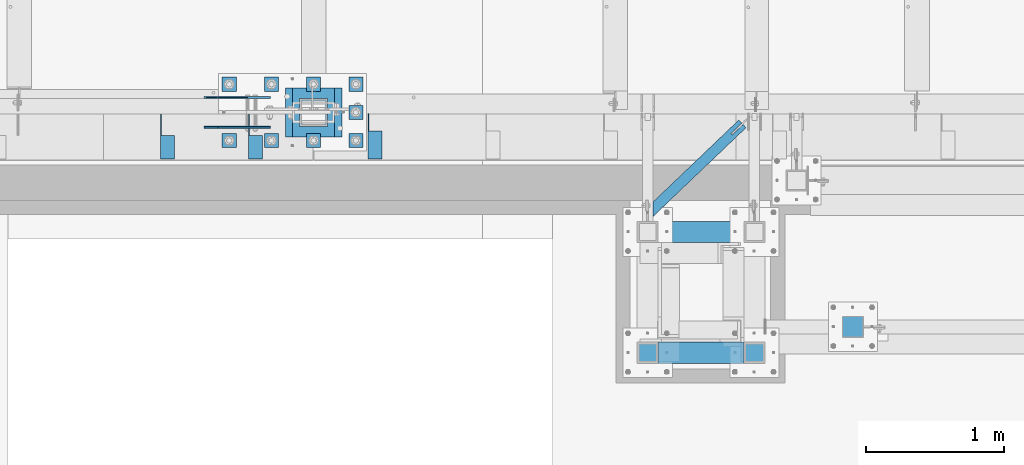
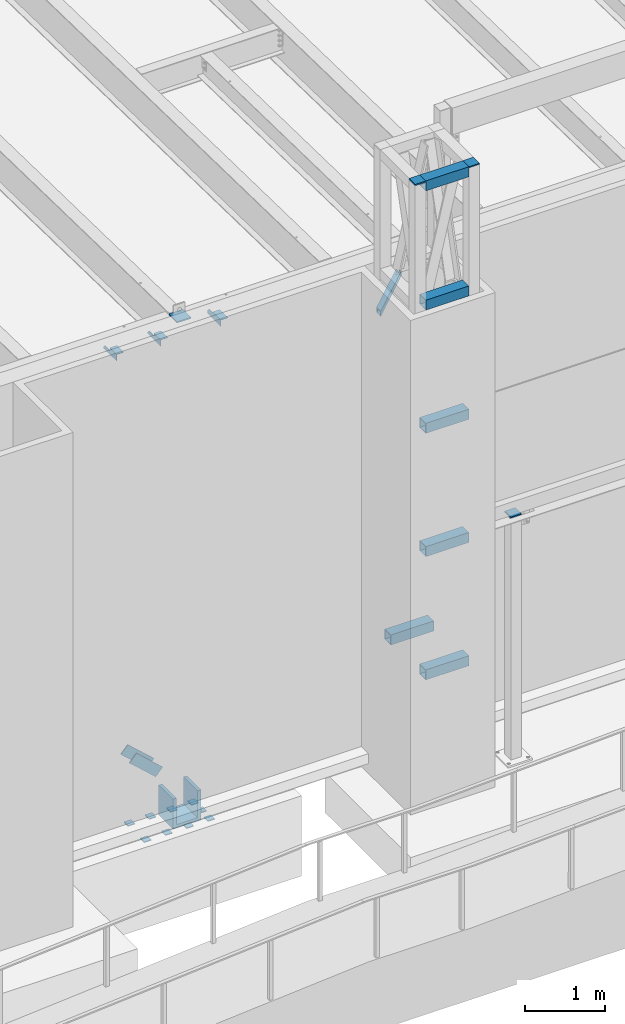
# One storey, part 1179 of 1763: 24 beams, 2 members, 9 elements without a shape of their own.
"""IFC2X3 building model written with IfcOpenShell, lengths in millimetres."""

from ifc_helpers import new_model, si_unit, frame, origin_with_axes, place, context, subcontext, project, spatial, faceted_brep, material, type_object, element, aggregate, save


model = new_model("IFC2X3")

# Units and contexts
model_context = context("Model", 3, precision=1e-05, world=origin_with_axes())
body_context = subcontext(model_context, "Body", "Model", "MODEL_VIEW")
ifc_project = project(units=[si_unit("LENGTHUNIT", "METRE", prefix="MILLI"), si_unit("AREAUNIT", "SQUARE_METRE"), si_unit("VOLUMEUNIT", "CUBIC_METRE"), si_unit("MASSUNIT", "GRAM", prefix="KILO"), si_unit("TIMEUNIT", "SECOND"), si_unit("PLANEANGLEUNIT", "RADIAN"), si_unit("SOLIDANGLEUNIT", "STERADIAN"), si_unit("THERMODYNAMICTEMPERATUREUNIT", "DEGREE_CELSIUS"), si_unit("LUMINOUSINTENSITYUNIT", "LUMEN")], contexts=[model_context])

# Site, building, storey
site_placement = place(None, origin_with_axes())
site = spatial("IfcSite", under=ifc_project, at=site_placement, CompositionType="ELEMENT")
building_placement = place(site_placement, origin_with_axes())
building = spatial("IfcBuilding", under=site, at=building_placement, Name="Undefined", CompositionType="ELEMENT")
storey_placement = place(building_placement, origin_with_axes())
storey = spatial("IfcBuildingStorey", under=building, at=storey_placement, Name="Undefined", CompositionType="ELEMENT", Elevation=0.0)

# Assembly, beam
assembly_1_placement = place(storey_placement, origin_with_axes())
assembly_1 = element("IfcElementAssembly", 1, at=assembly_1_placement, inside=storey, Name="BEAM", AssemblyPlace="NOTDEFINED", PredefinedType="RIGID_FRAME")
ifc_material_1 = material(Name="STEEL/A36")
beam_type_1 = type_object("IfcBeamType", Name="L4X4X1/4", PredefinedType="NOTDEFINED")
beam_1_placement = place(assembly_1_placement, frame((-72047.4055562792, -13723.1435701428, 12153.8999999998), z_axis=(0.0, 0.0, -1.0), x_axis=(0.0, -1.0, 0.0)))
beam_1 = element("IfcBeam", 2, at=beam_1_placement, type_object=beam_type_1, material=ifc_material_1, Name="BRACE", ObjectType="L4X4X1/4", context=body_context, shape_type="Brep", body=[
    faceted_brep([(31.7499999999673, 44.4499999999971, -31.7500001906901), (0.0, 44.4499999999971, -1.90690116141923e-07), (0.0, 50.8000000000029, -1.90690116141923e-07), (31.7499999999673, 50.8000000000029, -31.7500007627295), (-1.96450855582952e-10, 50.8000000000393, 50.7999999999374), (-1.81898940354586e-10, 44.4500000000371, 50.7999999999374), (329.406260681253, 44.4499999999971, 50.7999999999993), (329.406260681253, 50.8000000000029, 50.7999999999993), (329.406260681253, -50.8000000000029, -50.7999999999993), (329.406260681253, -50.8000000000029, -44.4500000000007), (127.793748474225, -50.8000000000029, -44.4500000000007), (127.793748474225, -50.8000000000029, -50.7999999999993), (329.406260681253, 50.8000000000029, -50.7999999999993), (127.793748474225, 50.8000000000029, -50.7999999999993), (329.406260681253, 44.4499999999971, -44.4500000000007), (127.793748474225, 44.4499999999971, -44.4500000000007), (127.793748474227, 44.4499999999971, -31.7500007627295), (127.793748474227, 50.8000000000029, -31.7500007627295)], [[[0, 1, 2, 3]], [[4, 5, 6, 7]], [[8, 9, 10, 11]], [[12, 8, 11, 13]], [[6, 14, 9, 8, 12, 7]], [[9, 14, 15, 10]], [[16, 17, 13, 11, 10, 15]], [[17, 16, 0, 3]], [[4, 7, 12, 13, 17, 3, 2]], [[5, 4, 2, 1]], [[16, 15, 14, 6, 5, 1, 0]]]),
])
aggregate(assembly_1, [beam_1])

# Assembly, beams
assembly_2_placement = place(storey_placement, origin_with_axes())
assembly_2 = element("IfcElementAssembly", 3, at=assembly_2_placement, inside=storey, Name="BEAM", AssemblyPlace="NOTDEFINED", PredefinedType="RIGID_FRAME")
beam_2_placement = place(assembly_2_placement, frame((-72911.0055562792, -13727.9060747206, 12153.8999999998), z_axis=(0.0, 0.0, -1.0), x_axis=(0.0, -1.0, 0.0)))
beam_2 = element("IfcBeam", 4, at=beam_2_placement, type_object=beam_type_1, material=ifc_material_1, Name="BRACE", ObjectType="L4X4X1/4", context=body_context, shape_type="Brep", body=[
    faceted_brep([(156.368743896541, 44.4499999999971, -6.34999904595679), (156.368743896541, 50.8000000000029, -6.34999904595679), (156.368743896533, 50.8000000000029, -50.7999999999993), (156.368743896533, -50.8000000000029, -50.7999999999993), (156.368743896535, -50.8000000000029, -44.4500000000007), (156.368743896535, 44.4499999999971, -44.4500000000007), (31.7499984742426, 44.4500000000007, -6.35000000027321), (31.7499984742426, 50.7999999999993, -6.35000038323415), (-1.81898940354586e-10, 44.4500000000371, 50.7999999999374), (-1.96450855582952e-10, 50.8000000000393, 50.7999999999374), (0.0, 50.7999999999993, 25.3999999997268), (0.0, 44.4500000000007, 25.3999999997268), (324.643737794, 44.4500000000007, 50.7999999999993), (324.643737794, 50.7999999999993, 50.7999999999993), (324.643737794, 44.4500000000007, -44.4500000000007), (324.643737794, -50.7999999999993, -44.4500000000007), (324.643737794, -50.7999999999993, -50.7999999999993), (324.643737794, 50.7999999999993, -50.7999999999993)], [[[0, 1, 2, 3, 4, 5]], [[6, 7, 1, 0]], [[8, 9, 10, 11]], [[9, 8, 12, 13]], [[12, 14, 15, 16, 17, 13]], [[15, 14, 5, 4]], [[16, 15, 4, 3]], [[17, 16, 3, 2]], [[10, 9, 13, 17, 2, 1, 7]], [[6, 11, 10, 7]], [[14, 12, 8, 11, 6, 0, 5]]]),
])
beam_3_placement = place(assembly_2_placement, frame((-73546.0055562792, -13727.9060747205, 12153.8999999998), z_axis=(0.0, 0.0, -1.0), x_axis=(0.0, -1.0, 0.0)))
beam_3 = element("IfcBeam", 5, at=beam_3_placement, type_object=beam_type_1, material=ifc_material_1, Name="BRACE", ObjectType="L4X4X1/4", context=body_context, shape_type="Brep", body=[
    faceted_brep([(156.368743896541, 44.4499999999971, -6.34999904595679), (156.368743896541, 50.8000000000029, -6.34999904595679), (156.368743896533, 50.8000000000029, -50.7999999999993), (156.368743896533, -50.8000000000029, -50.7999999999993), (156.368743896535, -50.8000000000029, -44.4500000000007), (156.368743896535, 44.4499999999971, -44.4500000000007), (31.7499984742426, 44.4500000000007, -6.35000000027321), (31.7499984742426, 50.7999999999993, -6.35000038323415), (-1.81898940354586e-10, 44.4500000000371, 50.7999999999374), (-1.96450855582952e-10, 50.8000000000393, 50.7999999999374), (0.0, 50.7999999999993, 25.3999999997268), (0.0, 44.4500000000007, 25.3999999997268), (324.643737794, 44.4500000000007, 50.7999999999993), (324.643737794, 50.7999999999993, 50.7999999999993), (324.643737794, 44.4500000000007, -44.4500000000007), (324.643737794, -50.7999999999993, -44.4500000000007), (324.643737794, -50.7999999999993, -50.7999999999993), (324.643737794, 50.7999999999993, -50.7999999999993)], [[[0, 1, 2, 3, 4, 5]], [[6, 7, 1, 0]], [[8, 9, 10, 11]], [[9, 8, 12, 13]], [[12, 14, 15, 16, 17, 13]], [[15, 14, 5, 4]], [[16, 15, 4, 3]], [[17, 16, 3, 2]], [[10, 9, 13, 17, 2, 1, 7]], [[6, 11, 10, 7]], [[14, 12, 8, 11, 6, 0, 5]]]),
])
aggregate(assembly_2, [beam_2, beam_3])

# Assembly, beam
assembly_3_placement = place(storey_placement, origin_with_axes())
assembly_3 = element("IfcElementAssembly", 6, at=assembly_3_placement, inside=storey, Name="BEAM", AssemblyPlace="NOTDEFINED", PredefinedType="RIGID_FRAME")
ifc_material_2 = material()
beam_type_2 = type_object("IfcBeamType", Name="HSS3X3X1/4", PredefinedType="NOTDEFINED")
beam_4_placement = place(assembly_3_placement, frame((-70078.0368719919, -14452.5992675181, 11825.2875), z_axis=(0.0, 0.0, 1.0), x_axis=(0.723320631729244, 0.690512319741514, 0.0)))
beam_4 = element("IfcBeam", 7, at=beam_4_placement, type_object=beam_type_2, material=ifc_material_2, Name="BEAM", ObjectType="HSS3X3X1/4", context=body_context, shape_type="Brep", body=[
    faceted_brep([(946.871423137745, 6.35000031700474, 38.1000000000004), (838.921423119747, 6.35000023934117, 38.1000000000004), (838.921423119747, 6.35000023933389, 31.75), (946.871423137745, 6.35000031700474, 31.75), (838.921423128813, -6.34999976050312, 38.1000000000004), (838.921423128799, -6.34999976049585, 31.75), (946.871423137658, -6.34999968283228, 38.1000000000004), (946.871423137658, -6.34999968283228, 31.75), (946.871423137745, 6.35000031700474, -31.75), (838.92142311966, 6.35000023933389, -31.75), (838.921423119638, 6.35000023933389, -38.1000000000004), (946.871423137745, 6.35000031700474, -38.1000000000004), (838.921423128711, -6.3499997605104, -31.75), (838.921423128697, -6.34999976049585, -38.1000000000004), (946.871423137658, -6.34999968283228, -31.75), (946.871423137658, -6.34999968283228, -38.1000000000004), (82.9836498048971, 31.75, 31.75), (82.9836498048971, 31.75, -31.75), (946.871423137905, 31.7500000014479, -31.75), (946.871423137905, 31.7500000014479, 31.75), (946.871423137498, -31.7499999982829, 31.75), (22.3638470663718, -31.7499999998254, 31.75), (22.3638470663718, -31.7499999998254, -31.75), (946.871423137498, -31.7499999982829, -31.75), (16.3018667925207, -38.0999999998094, -38.1000000000004), (16.3018667925207, -38.0999999998094, 38.1000000000004), (89.0456300787482, 38.099999999984, 38.1000000000004), (89.0456300787482, 38.099999999984, -38.1000000000004), (946.871423137949, 38.1000000014174, 38.1000000000004), (946.871423137949, 38.1000000014174, -38.1000000000004), (946.871423137447, -38.0999999982596, -38.1000000000004), (946.871423137447, -38.0999999982596, 38.1000000000004)], [[[0, 1, 2, 3]], [[4, 5, 2, 1]], [[6, 7, 5, 4]], [[8, 9, 10, 11]], [[12, 13, 10, 9]], [[14, 15, 13, 12]], [[16, 17, 18, 19]], [[20, 21, 16, 19, 3, 2, 5, 7]], [[22, 21, 20, 23]], [[9, 8, 18, 17, 22, 23, 14, 12]], [[24, 25, 26, 27], [16, 21, 22, 17]], [[27, 26, 28, 29]], [[19, 18, 8, 11, 29, 28, 0, 3]], [[30, 24, 27, 29, 11, 10, 13, 15]], [[25, 24, 30, 31]], [[1, 0, 28, 26, 25, 31, 6, 4]], [[31, 30, 15, 14, 23, 20, 7, 6]]]),
])
aggregate(assembly_3, [beam_4])

assembly_4_placement = place(storey_placement, origin_with_axes())
assembly_4 = element("IfcElementAssembly", 8, at=assembly_4_placement, inside=storey, Name="COLUMN", AssemblyPlace="NOTDEFINED", PredefinedType="RIGID_FRAME")
beam_type_3 = type_object("IfcBeamType", PredefinedType="NOTDEFINED")
beam_5_placement = place(assembly_4_placement, frame((-68595.3116892775, -15341.6000613784, 8778.875), z_axis=(1.0, 0.0, 0.0), x_axis=(0.0, 1.0, 0.0)))
beam_5 = element("IfcBeam", 9, at=beam_5_placement, type_object=beam_type_3, material=ifc_material_1, Name="PLATE", context=body_context, shape_type="Brep", body=[
    faceted_brep([(0.0, 9.52499999999964, -76.1999999999971), (0.0, 9.52499999999964, 76.1999999999971), (152.400000000001, 9.52499999999964, 76.1999999999971), (152.400000000001, 9.52499999999964, -76.1999999999971), (0.0, -9.52499999999964, 76.1999999999971), (152.400000000001, -9.52499999999964, 76.1999999999971), (0.0, -9.52499999999964, -76.1999999999971), (152.400000000001, -9.52499999999964, -76.1999999999971)], [[[0, 1, 2, 3]], [[1, 4, 5, 2]], [[4, 6, 7, 5]], [[6, 0, 3, 7]], [[5, 7, 3, 2]], [[6, 4, 1, 0]]]),
])
aggregate(assembly_4, [beam_5])

# Assembly, beams
assembly_5_placement = place(storey_placement, origin_with_axes())
assembly_5 = element("IfcElementAssembly", 10, at=assembly_5_placement, inside=storey, Name="FRAME", AssemblyPlace="NOTDEFINED", PredefinedType="RIGID_FRAME")
beam_6_placement = place(assembly_5_placement, frame((-69306.5116892775, -15528.9242675181, 14468.475), z_axis=(1.0, 0.0, 0.0), x_axis=(0.0, 1.0, 0.0)))
beam_6 = element("IfcBeam", 11, at=beam_6_placement, type_object=beam_type_3, material=ifc_material_1, Name="PLATE", context=body_context, shape_type="Brep", body=[
    faceted_brep([(0.0, 9.52499999999964, -76.1999999999971), (0.0, 9.52499999999964, 76.1999999999971), (152.400000000001, 9.52499999999964, 76.1999999999971), (152.400000000001, 9.52499999999964, -76.1999999999971), (0.0, -9.52499999999964, 76.1999999999971), (152.400000000001, -9.52499999999964, 76.1999999999971), (0.0, -9.52499999999964, -76.1999999999971), (152.400000000001, -9.52499999999964, -76.1999999999971)], [[[0, 1, 2, 3]], [[1, 4, 5, 2]], [[4, 6, 7, 5]], [[6, 0, 3, 7]], [[5, 7, 3, 2]], [[6, 4, 1, 0]]]),
])
beam_7_placement = place(assembly_5_placement, frame((-70078.03688459, -15528.9242675181, 14468.475), z_axis=(1.0, 0.0, 0.0), x_axis=(0.0, 1.0, 0.0)))
beam_7 = element("IfcBeam", 12, at=beam_7_placement, type_object=beam_type_3, material=ifc_material_1, Name="PLATE", context=body_context, shape_type="Brep", body=[
    faceted_brep([(0.0, 9.52499999999964, -76.1999999999971), (0.0, 9.52499999999964, 76.1999999999971), (152.400000000001, 9.52499999999964, 76.1999999999971), (152.400000000001, 9.52499999999964, -76.1999999999971), (0.0, -9.52499999999964, 76.1999999999971), (152.400000000001, -9.52499999999964, 76.1999999999971), (0.0, -9.52499999999964, -76.1999999999971), (152.400000000001, -9.52499999999964, -76.1999999999971)], [[[0, 1, 2, 3]], [[1, 4, 5, 2]], [[4, 6, 7, 5]], [[6, 0, 3, 7]], [[5, 7, 3, 2]], [[6, 4, 1, 0]]]),
])

# Assembly, members
assembly_6_placement = place(storey_placement, origin_with_axes())
assembly_6 = element("IfcElementAssembly", 13, at=assembly_6_placement, inside=storey, Name="V. BRACE", AssemblyPlace="NOTDEFINED", PredefinedType="RIGID_FRAME")
member_type = type_object("IfcMemberType", PredefinedType="NOTDEFINED")
member_1_placement = place(assembly_6_placement, frame((-72855.0508448272, -13823.95, 5460.72534249287), z_axis=(0.671476028756224, 0.0, 0.741026276730974), x_axis=(-0.741026276730974, 0.0, 0.671476028756224)))
member_1 = element("IfcMember", 14, at=member_1_placement, type_object=member_type, material=ifc_material_1, Name="PLATE", context=body_context, shape_type="Brep", body=[
    faceted_brep([(4.36557456851006e-11, 6.35000000000036, -76.2000000000044), (-4.72937244921923e-11, 6.35000000000036, 76.1999999999898), (507.999999999498, 6.35000000000036, 76.1999999995642), (507.999999999589, 6.35000000000036, -76.20000000043), (-4.72937244921923e-11, -6.35000000000036, 76.1999999999898), (507.999999999498, -6.35000000000036, 76.1999999995642), (4.36557456851006e-11, -6.35000000000036, -76.2000000000044), (507.999999999589, -6.35000000000036, -76.20000000043)], [[[0, 1, 2, 3]], [[1, 4, 5, 2]], [[4, 6, 7, 5]], [[6, 0, 3, 7]], [[5, 7, 3, 2]], [[6, 4, 1, 0]]]),
])
member_2_placement = place(assembly_6_placement, frame((-72855.0508448272, -13608.05, 5460.72534249287), z_axis=(0.671476028756224, 0.0, 0.741026276730974), x_axis=(-0.741026276730974, 0.0, 0.671476028756224)))
member_2 = element("IfcMember", 15, at=member_2_placement, type_object=member_type, material=ifc_material_1, Name="PLATE", context=body_context, shape_type="Brep", body=[
    faceted_brep([(4.36557456851006e-11, 6.35000000000036, -76.2000000000044), (-4.72937244921923e-11, 6.35000000000036, 76.1999999999898), (507.999999999498, 6.35000000000036, 76.1999999995642), (507.999999999589, 6.35000000000036, -76.20000000043), (-4.72937244921923e-11, -6.35000000000036, 76.1999999999898), (507.999999999498, -6.35000000000036, 76.1999999995642), (4.36557456851006e-11, -6.35000000000036, -76.2000000000044), (507.999999999589, -6.35000000000036, -76.20000000043)], [[[0, 1, 2, 3]], [[1, 4, 5, 2]], [[4, 6, 7, 5]], [[6, 0, 3, 7]], [[5, 7, 3, 2]], [[6, 4, 1, 0]]]),
])
aggregate(assembly_6, [member_1, member_2])

# Assembly, beams
assembly_7_placement = place(storey_placement, origin_with_axes())
assembly_7 = element("IfcElementAssembly", 16, at=assembly_7_placement, inside=storey, Name="TEMPLATE", AssemblyPlace="NOTDEFINED", PredefinedType="RIGID_FRAME")
beam_type_4 = type_object("IfcBeamType", PredefinedType="NOTDEFINED")
beam_8_placement = place(assembly_7_placement, frame((-73100.6372736984, -13970.0, 4578.35), z_axis=(1.0, 0.0, 0.0), x_axis=(0.0, 1.0, 0.0)))
beam_8 = element("IfcBeam", 17, at=beam_8_placement, type_object=beam_type_4, material=ifc_material_1, Name="WASHER PLATE", context=body_context, shape_type="Brep", body=[
    faceted_brep([(0.0, 6.35000000000036, -50.8000000000029), (0.0, 6.35000000000036, 50.8000000000029), (101.599999999999, 6.35000000000036, 50.8000000000029), (101.599999999999, 6.35000000000036, -50.8000000000029), (0.0, -6.35000000000036, 50.8000000000029), (101.599999999999, -6.35000000000036, 50.8000000000029), (0.0, -6.35000000000036, -50.8000000000029), (101.599999999999, -6.35000000000036, -50.8000000000029)], [[[0, 1, 2, 3]], [[1, 4, 5, 2]], [[4, 6, 7, 5]], [[6, 0, 3, 7]], [[5, 7, 3, 2]], [[6, 4, 1, 0]]]),
])
beam_9_placement = place(assembly_7_placement, frame((-72795.8372736984, -13970.0, 4578.35), z_axis=(1.0, 0.0, 0.0), x_axis=(0.0, 1.0, 0.0)))
beam_9 = element("IfcBeam", 18, at=beam_9_placement, type_object=beam_type_4, material=ifc_material_1, Name="WASHER PLATE", context=body_context, shape_type="Brep", body=[
    faceted_brep([(0.0, 6.35000000000036, -50.8000000000029), (0.0, 6.35000000000036, 50.8000000000029), (101.599999999999, 6.35000000000036, 50.8000000000029), (101.599999999999, 6.35000000000036, -50.8000000000029), (0.0, -6.35000000000036, 50.8000000000029), (101.599999999999, -6.35000000000036, 50.8000000000029), (0.0, -6.35000000000036, -50.8000000000029), (101.599999999999, -6.35000000000036, -50.8000000000029)], [[[0, 1, 2, 3]], [[1, 4, 5, 2]], [[4, 6, 7, 5]], [[6, 0, 3, 7]], [[5, 7, 3, 2]], [[6, 4, 1, 0]]]),
])
beam_10_placement = place(assembly_7_placement, frame((-72491.0372736984, -13970.0, 4578.35), z_axis=(1.0, 0.0, 0.0), x_axis=(0.0, 1.0, 0.0)))
beam_10 = element("IfcBeam", 19, at=beam_10_placement, type_object=beam_type_4, material=ifc_material_1, Name="WASHER PLATE", context=body_context, shape_type="Brep", body=[
    faceted_brep([(0.0, 6.35000000000036, -50.8000000000029), (0.0, 6.35000000000036, 50.8000000000029), (101.599999999999, 6.35000000000036, 50.8000000000029), (101.599999999999, 6.35000000000036, -50.8000000000029), (0.0, -6.35000000000036, 50.8000000000029), (101.599999999999, -6.35000000000036, 50.8000000000029), (0.0, -6.35000000000036, -50.8000000000029), (101.599999999999, -6.35000000000036, -50.8000000000029)], [[[0, 1, 2, 3]], [[1, 4, 5, 2]], [[4, 6, 7, 5]], [[6, 0, 3, 7]], [[5, 7, 3, 2]], [[6, 4, 1, 0]]]),
])
beam_11_placement = place(assembly_7_placement, frame((-72186.2372736984, -13970.0, 4578.35), z_axis=(1.0, 0.0, 0.0), x_axis=(0.0, 1.0, 0.0)))
beam_11 = element("IfcBeam", 20, at=beam_11_placement, type_object=beam_type_4, material=ifc_material_1, Name="WASHER PLATE", context=body_context, shape_type="Brep", body=[
    faceted_brep([(0.0, 6.35000000000036, -50.8000000000029), (0.0, 6.35000000000036, 50.8000000000029), (101.599999999999, 6.35000000000036, 50.8000000000029), (101.599999999999, 6.35000000000036, -50.8000000000029), (0.0, -6.35000000000036, 50.8000000000029), (101.599999999999, -6.35000000000036, 50.8000000000029), (0.0, -6.35000000000036, -50.8000000000029), (101.599999999999, -6.35000000000036, -50.8000000000029)], [[[0, 1, 2, 3]], [[1, 4, 5, 2]], [[4, 6, 7, 5]], [[6, 0, 3, 7]], [[5, 7, 3, 2]], [[6, 4, 1, 0]]]),
])
beam_12_placement = place(assembly_7_placement, frame((-72186.2372736984, -13766.8, 4578.35), z_axis=(1.0, 0.0, 0.0), x_axis=(0.0, 1.0, 0.0)))
beam_12 = element("IfcBeam", 21, at=beam_12_placement, type_object=beam_type_4, material=ifc_material_1, Name="WASHER PLATE", context=body_context, shape_type="Brep", body=[
    faceted_brep([(0.0, 6.35000000000036, -50.8000000000029), (0.0, 6.35000000000036, 50.8000000000029), (101.599999999999, 6.35000000000036, 50.8000000000029), (101.599999999999, 6.35000000000036, -50.8000000000029), (0.0, -6.35000000000036, 50.8000000000029), (101.599999999999, -6.35000000000036, 50.8000000000029), (0.0, -6.35000000000036, -50.8000000000029), (101.599999999999, -6.35000000000036, -50.8000000000029)], [[[0, 1, 2, 3]], [[1, 4, 5, 2]], [[4, 6, 7, 5]], [[6, 0, 3, 7]], [[5, 7, 3, 2]], [[6, 4, 1, 0]]]),
])
beam_13_placement = place(assembly_7_placement, frame((-73100.6372736984, -13563.6, 4578.35), z_axis=(1.0, 0.0, 0.0), x_axis=(0.0, 1.0, 0.0)))
beam_13 = element("IfcBeam", 22, at=beam_13_placement, type_object=beam_type_4, material=ifc_material_1, Name="WASHER PLATE", context=body_context, shape_type="Brep", body=[
    faceted_brep([(0.0, 6.35000000000036, -50.8000000000029), (0.0, 6.35000000000036, 50.8000000000029), (101.599999999999, 6.35000000000036, 50.8000000000029), (101.599999999999, 6.35000000000036, -50.8000000000029), (0.0, -6.35000000000036, 50.8000000000029), (101.599999999999, -6.35000000000036, 50.8000000000029), (0.0, -6.35000000000036, -50.8000000000029), (101.599999999999, -6.35000000000036, -50.8000000000029)], [[[0, 1, 2, 3]], [[1, 4, 5, 2]], [[4, 6, 7, 5]], [[6, 0, 3, 7]], [[5, 7, 3, 2]], [[6, 4, 1, 0]]]),
])
beam_14_placement = place(assembly_7_placement, frame((-72795.8372736984, -13563.6, 4578.35), z_axis=(1.0, 0.0, 0.0), x_axis=(0.0, 1.0, 0.0)))
beam_14 = element("IfcBeam", 23, at=beam_14_placement, type_object=beam_type_4, material=ifc_material_1, Name="WASHER PLATE", context=body_context, shape_type="Brep", body=[
    faceted_brep([(0.0, 6.35000000000036, -50.8000000000029), (0.0, 6.35000000000036, 50.8000000000029), (101.599999999999, 6.35000000000036, 50.8000000000029), (101.599999999999, 6.35000000000036, -50.8000000000029), (0.0, -6.35000000000036, 50.8000000000029), (101.599999999999, -6.35000000000036, 50.8000000000029), (0.0, -6.35000000000036, -50.8000000000029), (101.599999999999, -6.35000000000036, -50.8000000000029)], [[[0, 1, 2, 3]], [[1, 4, 5, 2]], [[4, 6, 7, 5]], [[6, 0, 3, 7]], [[5, 7, 3, 2]], [[6, 4, 1, 0]]]),
])
beam_15_placement = place(assembly_7_placement, frame((-72491.0372736984, -13563.6, 4578.35), z_axis=(1.0, 0.0, 0.0), x_axis=(0.0, 1.0, 0.0)))
beam_15 = element("IfcBeam", 24, at=beam_15_placement, type_object=beam_type_4, material=ifc_material_1, Name="WASHER PLATE", context=body_context, shape_type="Brep", body=[
    faceted_brep([(0.0, 6.35000000000036, -50.8000000000029), (0.0, 6.35000000000036, 50.8000000000029), (101.599999999999, 6.35000000000036, 50.8000000000029), (101.599999999999, 6.35000000000036, -50.8000000000029), (0.0, -6.35000000000036, 50.8000000000029), (101.599999999999, -6.35000000000036, 50.8000000000029), (0.0, -6.35000000000036, -50.8000000000029), (101.599999999999, -6.35000000000036, -50.8000000000029)], [[[0, 1, 2, 3]], [[1, 4, 5, 2]], [[4, 6, 7, 5]], [[6, 0, 3, 7]], [[5, 7, 3, 2]], [[6, 4, 1, 0]]]),
])
beam_16_placement = place(assembly_7_placement, frame((-72186.2372736984, -13563.6, 4578.35), z_axis=(1.0, 0.0, 0.0), x_axis=(0.0, 1.0, 0.0)))
beam_16 = element("IfcBeam", 25, at=beam_16_placement, type_object=beam_type_4, material=ifc_material_1, Name="WASHER PLATE", context=body_context, shape_type="Brep", body=[
    faceted_brep([(0.0, 6.35000000000036, -50.8000000000029), (0.0, 6.35000000000036, 50.8000000000029), (101.599999999999, 6.35000000000036, 50.8000000000029), (101.599999999999, 6.35000000000036, -50.8000000000029), (0.0, -6.35000000000036, 50.8000000000029), (101.599999999999, -6.35000000000036, 50.8000000000029), (0.0, -6.35000000000036, -50.8000000000029), (101.599999999999, -6.35000000000036, -50.8000000000029)], [[[0, 1, 2, 3]], [[1, 4, 5, 2]], [[4, 6, 7, 5]], [[6, 0, 3, 7]], [[5, 7, 3, 2]], [[6, 4, 1, 0]]]),
])
aggregate(assembly_7, [beam_8, beam_9, beam_10, beam_11, beam_12, beam_13, beam_14, beam_15, beam_16])

# Beam
beam_type_5 = type_object("IfcBeamType", Name="HSS6X6X1/4", PredefinedType="NOTDEFINED")
beam_17_placement = place(assembly_5_placement, frame((-70078.0366892775, -14579.5992675181, 6966.74375), z_axis=(0.0, 0.0, 1.0), x_axis=(1.0, 0.0, 0.0)))
beam_17 = element("IfcBeam", 26, at=beam_17_placement, type_object=beam_type_5, material=ifc_material_2, Name="BEAM", ObjectType="HSS6X6X1/4", context=body_context, shape_type="Brep", body=[
    faceted_brep([(76.1998046874942, 69.8500000000004, -69.8500000000004), (76.1998046874942, -69.8500000000004, -69.8500000000004), (695.325000000012, -69.8500000000004, -69.8500000000004), (695.325000000012, 69.8500000000004, -69.8500000000004), (76.1998046874942, -69.8500000000004, 69.8500000000004), (695.325000000012, -69.8500000000004, 69.8500000000004), (76.1998046874942, 69.8500000000004, 69.8500000000004), (695.325000000012, 69.8500000000004, 69.8500000000004), (76.1998535156017, 76.2000000000007, -76.1999999999998), (76.1998535156017, 76.2000000000007, 76.1999999999998), (695.325048828119, 76.2000000000007, 76.1999999999998), (695.325048828119, 76.2000000000007, -76.1999999999998), (76.1998535156017, -76.2000000000007, 76.1999999999998), (695.325048828119, -76.2000000000007, 76.1999999999998), (76.1998535156017, -76.2000000000007, -76.1999999999998), (695.325048828119, -76.2000000000007, -76.1999999999998)], [[[0, 1, 2, 3]], [[1, 4, 5, 2]], [[4, 6, 7, 5]], [[6, 0, 3, 7]], [[8, 9, 10, 11]], [[9, 12, 13, 10]], [[12, 14, 15, 13]], [[14, 8, 11, 15]], [[13, 15, 11, 10], [5, 7, 3, 2]], [[14, 12, 9, 8], [6, 4, 1, 0]]]),
])

beam_18_placement = place(assembly_5_placement, frame((-70078.0366892775, -15452.7242675181, 6966.74375), z_axis=(0.0, 0.0, 1.0), x_axis=(1.0, 0.0, 0.0)))
beam_18 = element("IfcBeam", 27, at=beam_18_placement, type_object=beam_type_5, material=ifc_material_2, Name="BEAM", ObjectType="HSS6X6X1/4", context=body_context, shape_type="Brep", body=[
    faceted_brep([(76.1998046874942, 69.8500000000004, -69.8500000000004), (76.1998046874942, -69.8500000000004, -69.8500000000004), (695.325000000012, -69.8500000000004, -69.8500000000004), (695.325000000012, 69.8500000000004, -69.8500000000004), (76.1998046874942, -69.8500000000004, 69.8500000000004), (695.325000000012, -69.8500000000004, 69.8500000000004), (76.1998046874942, 69.8500000000004, 69.8500000000004), (695.325000000012, 69.8500000000004, 69.8500000000004), (76.1998535156017, 76.2000000000007, -76.1999999999998), (76.1998535156017, 76.2000000000007, 76.1999999999998), (695.325048828119, 76.2000000000007, 76.1999999999998), (695.325048828119, 76.2000000000007, -76.1999999999998), (76.1998535156017, -76.2000000000007, 76.1999999999998), (695.325048828119, -76.2000000000007, 76.1999999999998), (76.1998535156017, -76.2000000000007, -76.1999999999998), (695.325048828119, -76.2000000000007, -76.1999999999998)], [[[0, 1, 2, 3]], [[1, 4, 5, 2]], [[4, 6, 7, 5]], [[6, 0, 3, 7]], [[8, 9, 10, 11]], [[9, 12, 13, 10]], [[12, 14, 15, 13]], [[14, 8, 11, 15]], [[13, 15, 11, 10], [5, 7, 3, 2]], [[14, 12, 9, 8], [6, 4, 1, 0]]]),
])

beam_19_placement = place(assembly_5_placement, frame((-70078.0366892775, -15452.7242675181, 8840.7875), z_axis=(0.0, 0.0, 1.0), x_axis=(1.0, 0.0, 0.0)))
beam_19 = element("IfcBeam", 28, at=beam_19_placement, type_object=beam_type_5, material=ifc_material_2, Name="BEAM", ObjectType="HSS6X6X1/4", context=body_context, shape_type="Brep", body=[
    faceted_brep([(76.1998046874942, 69.8500000000004, -69.8500000000004), (76.1998046874942, -69.8500000000004, -69.8500000000004), (695.325000000012, -69.8500000000004, -69.8500000000004), (695.325000000012, 69.8500000000004, -69.8500000000004), (76.1998046874942, -69.8500000000004, 69.8500000000004), (695.325000000012, -69.8500000000004, 69.8500000000004), (76.1998046874942, 69.8500000000004, 69.8500000000004), (695.325000000012, 69.8500000000004, 69.8500000000004), (76.1998535156017, 76.2000000000007, -76.1999999999998), (76.1998535156017, 76.2000000000007, 76.1999999999998), (695.325048828119, 76.2000000000007, 76.1999999999998), (695.325048828119, 76.2000000000007, -76.1999999999998), (76.1998535156017, -76.2000000000007, 76.1999999999998), (695.325048828119, -76.2000000000007, 76.1999999999998), (76.1998535156017, -76.2000000000007, -76.1999999999998), (695.325048828119, -76.2000000000007, -76.1999999999998)], [[[0, 1, 2, 3]], [[1, 4, 5, 2]], [[4, 6, 7, 5]], [[6, 0, 3, 7]], [[8, 9, 10, 11]], [[9, 12, 13, 10]], [[12, 14, 15, 13]], [[14, 8, 11, 15]], [[13, 15, 11, 10], [5, 7, 3, 2]], [[14, 12, 9, 8], [6, 4, 1, 0]]]),
])

beam_20_placement = place(assembly_5_placement, frame((-70078.0366892775, -15452.7242675181, 10714.83125), z_axis=(0.0, 0.0, 1.0), x_axis=(1.0, 0.0, 0.0)))
beam_20 = element("IfcBeam", 29, at=beam_20_placement, type_object=beam_type_5, material=ifc_material_2, Name="BEAM", ObjectType="HSS6X6X1/4", context=body_context, shape_type="Brep", body=[
    faceted_brep([(76.1998046874942, 69.8500000000004, -69.8500000000004), (76.1998046874942, -69.8500000000004, -69.8500000000004), (695.325000000012, -69.8500000000004, -69.8500000000004), (695.325000000012, 69.8500000000004, -69.8500000000004), (76.1998046874942, -69.8500000000004, 69.8500000000004), (695.325000000012, -69.8500000000004, 69.8500000000004), (76.1998046874942, 69.8500000000004, 69.8500000000004), (695.325000000012, 69.8500000000004, 69.8500000000004), (76.1998535156017, 76.2000000000007, -76.1999999999998), (76.1998535156017, 76.2000000000007, 76.1999999999998), (695.325048828119, 76.2000000000007, 76.1999999999998), (695.325048828119, 76.2000000000007, -76.1999999999998), (76.1998535156017, -76.2000000000007, 76.1999999999998), (695.325048828119, -76.2000000000007, 76.1999999999998), (76.1998535156017, -76.2000000000007, -76.1999999999998), (695.325048828119, -76.2000000000007, -76.1999999999998)], [[[0, 1, 2, 3]], [[1, 4, 5, 2]], [[4, 6, 7, 5]], [[6, 0, 3, 7]], [[8, 9, 10, 11]], [[9, 12, 13, 10]], [[12, 14, 15, 13]], [[14, 8, 11, 15]], [[13, 15, 11, 10], [5, 7, 3, 2]], [[14, 12, 9, 8], [6, 4, 1, 0]]]),
])

beam_21_placement = place(assembly_5_placement, frame((-70078.0366892775, -15452.7242675181, 14401.8), z_axis=(0.0, 0.0, 1.0), x_axis=(1.0, 0.0, 0.0)))
beam_21 = element("IfcBeam", 30, at=beam_21_placement, type_object=beam_type_5, material=ifc_material_2, Name="BEAM", ObjectType="HSS6X6X1/4", context=body_context, shape_type="Brep", body=[
    faceted_brep([(76.1998046874942, 69.8500000000004, -69.8500000000004), (76.1998046874942, -69.8500000000004, -69.8500000000004), (695.325000000012, -69.8500000000004, -69.8500000000004), (695.325000000012, 69.8500000000004, -69.8500000000004), (76.1998046874942, -69.8500000000004, 69.8500000000004), (695.325000000012, -69.8500000000004, 69.8500000000004), (76.1998046874942, 69.8500000000004, 69.8500000000004), (695.325000000012, 69.8500000000004, 69.8500000000004), (76.1998535156017, 76.2000000000007, -76.1999999999998), (76.1998535156017, 76.2000000000007, 76.1999999999998), (695.325048828119, 76.2000000000007, 76.1999999999998), (695.325048828119, 76.2000000000007, -76.1999999999998), (76.1998535156017, -76.2000000000007, 76.1999999999998), (695.325048828119, -76.2000000000007, 76.1999999999998), (76.1998535156017, -76.2000000000007, -76.1999999999998), (695.325048828119, -76.2000000000007, -76.1999999999998)], [[[0, 1, 2, 3]], [[1, 4, 5, 2]], [[4, 6, 7, 5]], [[6, 0, 3, 7]], [[8, 9, 10, 11]], [[9, 12, 13, 10]], [[12, 14, 15, 13]], [[14, 8, 11, 15]], [[13, 15, 11, 10], [5, 7, 3, 2]], [[14, 12, 9, 8], [6, 4, 1, 0]]]),
])

beam_22_placement = place(assembly_5_placement, frame((-70078.0366892775, -15452.7242675181, 12588.875), z_axis=(0.0, 0.0, 1.0), x_axis=(1.0, 0.0, 0.0)))
beam_22 = element("IfcBeam", 31, at=beam_22_placement, type_object=beam_type_5, material=ifc_material_2, Name="BEAM", ObjectType="HSS6X6X1/4", context=body_context, shape_type="Brep", body=[
    faceted_brep([(76.1998046874942, 69.8500000000004, -69.8500000000004), (76.1998046874942, -69.8500000000004, -69.8500000000004), (695.325000000012, -69.8500000000004, -69.8500000000004), (695.325000000012, 69.8500000000004, -69.8500000000004), (76.1998046874942, -69.8500000000004, 69.8500000000004), (695.325000000012, -69.8500000000004, 69.8500000000004), (76.1998046874942, 69.8500000000004, 69.8500000000004), (695.325000000012, 69.8500000000004, 69.8500000000004), (76.1998535156017, 76.2000000000007, -76.1999999999998), (76.1998535156017, 76.2000000000007, 76.1999999999998), (695.325048828119, 76.2000000000007, 76.1999999999998), (695.325048828119, 76.2000000000007, -76.1999999999998), (76.1998535156017, -76.2000000000007, 76.1999999999998), (695.325048828119, -76.2000000000007, 76.1999999999998), (76.1998535156017, -76.2000000000007, -76.1999999999998), (695.325048828119, -76.2000000000007, -76.1999999999998)], [[[0, 1, 2, 3]], [[1, 4, 5, 2]], [[4, 6, 7, 5]], [[6, 0, 3, 7]], [[8, 9, 10, 11]], [[9, 12, 13, 10]], [[12, 14, 15, 13]], [[14, 8, 11, 15]], [[13, 15, 11, 10], [5, 7, 3, 2]], [[14, 12, 9, 8], [6, 4, 1, 0]]]),
])

aggregate(assembly_5, [beam_17, beam_18, beam_19, beam_20, beam_6, beam_7, beam_21, beam_22])

# Assembly, beam
assembly_8_placement = place(storey_placement, origin_with_axes())
assembly_8 = element("IfcElementAssembly", 32, at=assembly_8_placement, inside=storey, Name="GROUT", AssemblyPlace="NOTDEFINED", PredefinedType="REINFORCEMENT_UNIT")
ifc_material_3 = material(Name="CONCRETE/GROUT")
beam_type_6 = type_object("IfcBeamType", PredefinedType="NOTDEFINED")
beam_23_placement = place(assembly_8_placement, frame((-72668.8372736983, -13716.0325861983, 5029.19999389648), z_axis=(0.0, 1.0, 0.0), x_axis=(0.0, 0.0, -1.0)))
beam_23 = element("IfcBeam", 33, at=beam_23_placement, type_object=beam_type_6, material=ifc_material_3, Name="GROUT", context=body_context, shape_type="Brep", body=[
    faceted_brep([(0.0, -25.4000000000015, -177.799999999999), (0.0, -25.4000000000015, 177.799999999999), (0.0, 25.4000000000015, 177.799999999999), (0.0, 25.4000000000015, -177.799999999999), (457.199993896478, 25.4000000000015, 177.799999999999), (457.199993896478, 25.4000000000015, -177.799999999999), (406.399993896479, -25.4000000000015, -177.799999999999), (406.399993896479, -25.4000000000015, 177.799999999999), (457.199993896478, -380.999987792959, 177.799999999999), (457.199993896478, -380.999987792959, -177.799999999999), (406.399993896479, -330.199987792956, -177.799999999999), (406.399993896479, -330.199987792956, 177.799999999999), (3.63797880709171e-12, -380.999987792959, 177.799999999999), (3.63797880709171e-12, -380.999987792959, -177.799999999999), (3.63797880709171e-12, -330.199987792956, 177.799999999999), (3.63797880709171e-12, -330.199987792956, -177.799999999999)], [[[0, 1, 2, 3]], [[3, 2, 4, 5]], [[1, 0, 6, 7]], [[5, 4, 8, 9]], [[7, 6, 10, 11]], [[9, 8, 12, 13]], [[8, 4, 2, 1, 7, 11, 14, 12]], [[11, 10, 15, 14]], [[10, 6, 0, 3, 5, 9, 13, 15]], [[14, 15, 13, 12]]]),
])
aggregate(assembly_8, [beam_23])

assembly_9_placement = place(storey_placement, origin_with_axes())
assembly_9 = element("IfcElementAssembly", 34, at=assembly_9_placement, inside=storey, Name="COLUMN", AssemblyPlace="NOTDEFINED", PredefinedType="RIGID_FRAME")
ifc_material_4 = material(Name="STEEL/A572-50")
beam_type_7 = type_object("IfcBeamType", PredefinedType="NOTDEFINED")
beam_24_placement = place(assembly_9_placement, frame((-72491.0372736984, -13817.6, 12195.175), z_axis=(1.0, 0.0, 0.0), x_axis=(0.0, 1.0, 0.0)))
beam_24 = element("IfcBeam", 35, at=beam_24_placement, type_object=beam_type_7, material=ifc_material_4, Name="PLATE", context=body_context, shape_type="Brep", body=[
    faceted_brep([(0.0, 9.52499999999964, -101.599999999999), (0.0, 9.52499999999964, 101.599999999999), (203.200000000001, 9.52499999999964, 101.599999999999), (203.200000000001, 9.52499999999964, -101.599999999999), (0.0, -9.52499999999964, 101.599999999999), (203.200000000001, -9.52499999999964, 101.599999999999), (0.0, -9.52499999999964, -101.599999999999), (203.200000000001, -9.52499999999964, -101.599999999999)], [[[0, 1, 2, 3]], [[1, 4, 5, 2]], [[4, 6, 7, 5]], [[6, 0, 3, 7]], [[5, 7, 3, 2]], [[6, 4, 1, 0]]]),
])
aggregate(assembly_9, [beam_24])

save(model, "model.ifc")
